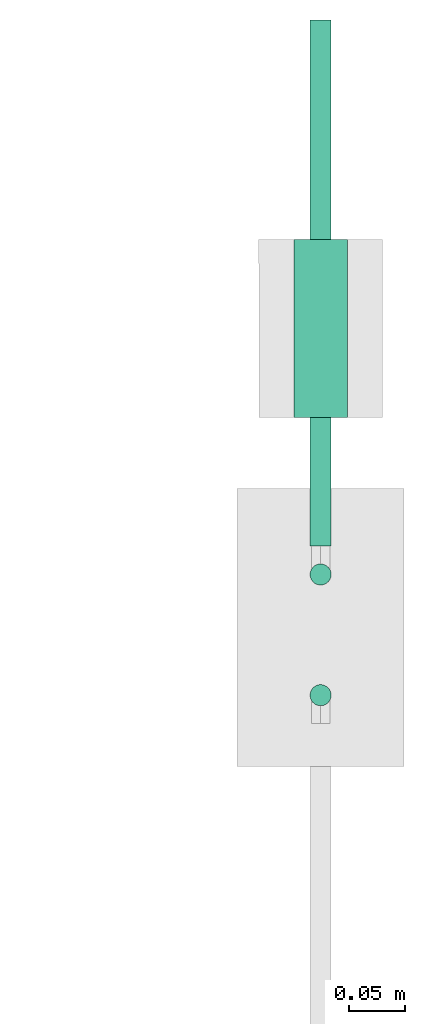
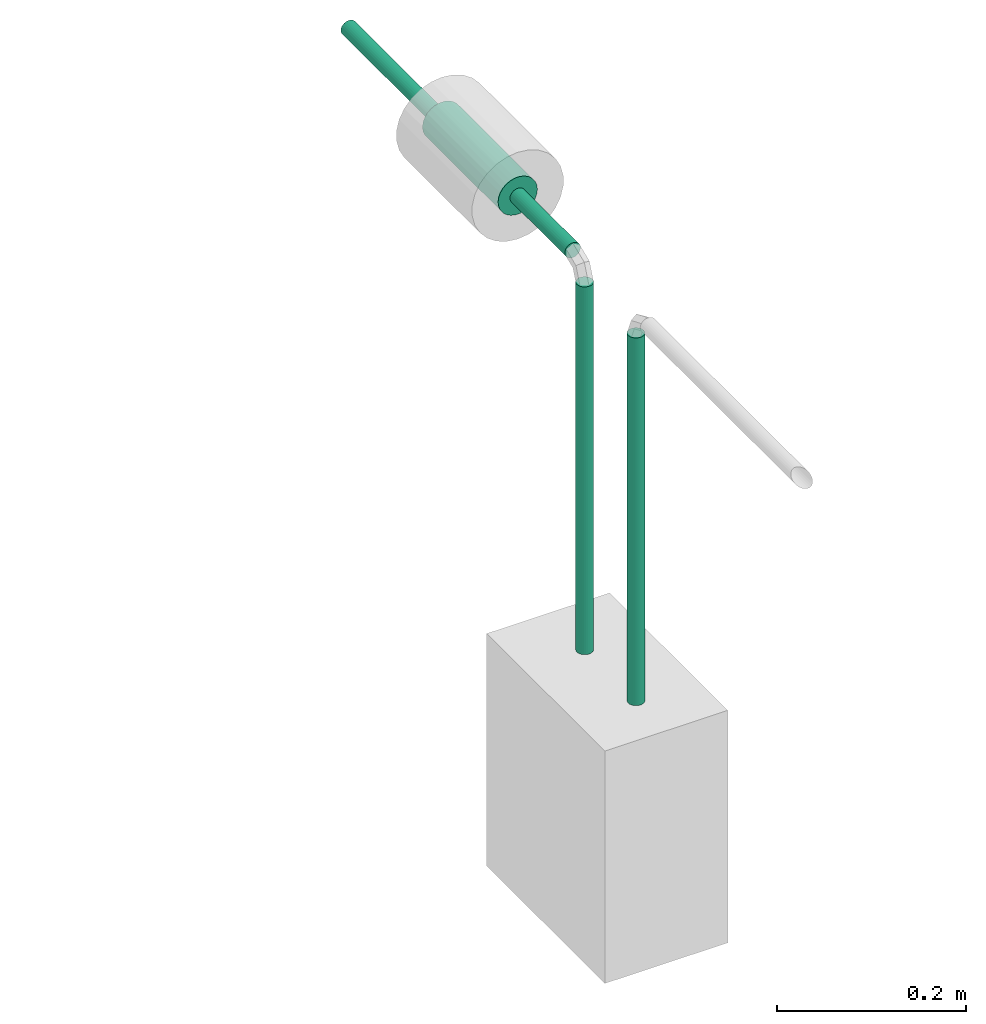
# One storey, part 28 of 45: 4 flow segments.
"""IFC2X3 building model written with IfcOpenShell, lengths in millimetres."""

from ifc_helpers import new_model, entity, si_unit, converted_unit, derived_unit, direction, frame, origin, origin_2d_with_axis, place, context, subcontext, project, spatial, circle, extrude, type_object, element, save


model = new_model("IFC2X3")

# Units and contexts
model_context = context("Model", 3, precision=0.01, world=origin(), true_north=direction((6.12303176911189e-17, 1.0)))
body_context = subcontext(model_context, "Body", "Model", "MODEL_VIEW")
ifc_project = project(units=[si_unit("LENGTHUNIT", "METRE", prefix="MILLI"), si_unit("AREAUNIT", "SQUARE_METRE"), si_unit("VOLUMEUNIT", "CUBIC_METRE"), converted_unit("PLANEANGLEUNIT", "DEGREE", entity("IfcRatioMeasure", 0.0174532925199433), si_unit("PLANEANGLEUNIT", "RADIAN"), dimensions=[0, 0, 0, 0, 0, 0, 0]), si_unit("MASSUNIT", "GRAM", prefix="KILO"), derived_unit("MASSDENSITYUNIT", [(si_unit("MASSUNIT", "GRAM", prefix="KILO"), 1), (si_unit("LENGTHUNIT", "METRE"), -3)]), derived_unit("MOMENTOFINERTIAUNIT", [(si_unit("LENGTHUNIT", "METRE"), 4)]), si_unit("TIMEUNIT", "SECOND"), si_unit("FREQUENCYUNIT", "HERTZ"), si_unit("THERMODYNAMICTEMPERATUREUNIT", "DEGREE_CELSIUS"), derived_unit("THERMALTRANSMITTANCEUNIT", [(si_unit("MASSUNIT", "GRAM", prefix="KILO"), 1), (si_unit("THERMODYNAMICTEMPERATUREUNIT", "KELVIN"), -1), (si_unit("TIMEUNIT", "SECOND"), -3)]), derived_unit("VOLUMETRICFLOWRATEUNIT", [(si_unit("LENGTHUNIT", "METRE"), 3), (si_unit("TIMEUNIT", "SECOND"), -1)]), derived_unit("MASSFLOWRATEUNIT", [(si_unit("MASSUNIT", "GRAM", prefix="KILO"), 1), (si_unit("TIMEUNIT", "SECOND"), -1)]), derived_unit("ROTATIONALFREQUENCYUNIT", [(si_unit("TIMEUNIT", "SECOND"), -1)]), si_unit("ELECTRICCURRENTUNIT", "AMPERE"), si_unit("ELECTRICVOLTAGEUNIT", "VOLT"), si_unit("POWERUNIT", "WATT"), si_unit("FORCEUNIT", "NEWTON", prefix="KILO"), si_unit("ILLUMINANCEUNIT", "LUX"), si_unit("LUMINOUSFLUXUNIT", "LUMEN"), si_unit("LUMINOUSINTENSITYUNIT", "CANDELA"), derived_unit("USERDEFINED", [(si_unit("MASSUNIT", "GRAM", prefix="KILO"), -1), (si_unit("LENGTHUNIT", "METRE"), -2), (si_unit("TIMEUNIT", "SECOND"), 3), (si_unit("LUMINOUSFLUXUNIT", "LUMEN"), 1)]), derived_unit("LINEARVELOCITYUNIT", [(si_unit("LENGTHUNIT", "METRE"), 1), (si_unit("TIMEUNIT", "SECOND"), -1)]), si_unit("PRESSUREUNIT", "PASCAL"), derived_unit("USERDEFINED", [(si_unit("LENGTHUNIT", "METRE"), -2), (si_unit("MASSUNIT", "GRAM", prefix="KILO"), 1), (si_unit("TIMEUNIT", "SECOND"), -2)]), derived_unit("LINEARFORCEUNIT", [(si_unit("MASSUNIT", "GRAM", prefix="KILO"), 1), (si_unit("LENGTHUNIT", "METRE"), 1), (si_unit("TIMEUNIT", "SECOND"), -2), (si_unit("LENGTHUNIT", "METRE"), -1)]), derived_unit("PLANARFORCEUNIT", [(si_unit("MASSUNIT", "GRAM", prefix="KILO"), 1), (si_unit("LENGTHUNIT", "METRE"), 1), (si_unit("TIMEUNIT", "SECOND"), -2), (si_unit("LENGTHUNIT", "METRE"), -2)])], contexts=[model_context])

# Site, building, storey
site_placement = place(None, frame((-24836.06, 8968.75, 0.0)))
site = spatial("IfcSite", under=ifc_project, at=site_placement, CompositionType="ELEMENT")
building_placement = place(site_placement, origin())
building = spatial("IfcBuilding", under=site, at=building_placement, CompositionType="ELEMENT")
storey_placement = place(building_placement, frame((0.0, 0.0, -4200.0)))
storey = spatial("IfcBuildingStorey", under=building, at=storey_placement, CompositionType="ELEMENT", Elevation=-4200.0)

# Flow segments
pipe_segment_type_1 = type_object("IfcPipeSegmentType", PredefinedType="NOTDEFINED")
flow_segment_1_placement = place(storey_placement, frame((98110.13, 1125.13, 1700.0)))
element("IfcFlowSegment", 1, at=flow_segment_1_placement, inside=storey, type_object=pipe_segment_type_1, context=body_context, shape_type="SweptSolid", body=[
    extrude(circle(Radius=9.525, at=origin_2d_with_axis()), frame((11.12, 11.12, 0.0)), (0.0, 0.0, 1.0), 474.599999999999),
])
flow_segment_2_placement = place(storey_placement, frame((98110.13, 1233.72, 1700.0)))
element("IfcFlowSegment", 2, at=flow_segment_2_placement, inside=storey, type_object=pipe_segment_type_1, context=body_context, shape_type="SweptSolid", body=[
    extrude(circle(Radius=9.525, at=origin_2d_with_axis()), frame((11.12, 11.12, 0.0)), (0.0, 0.0, 1.0), 474.600000000001),
])
flow_segment_3_placement = place(storey_placement, frame((98110.02, 1270.24, 2188.88)))
element("IfcFlowSegment", 3, at=flow_segment_3_placement, inside=storey, type_object=pipe_segment_type_1, context=body_context, shape_type="SweptSolid", body=[
    extrude(circle(Radius=9.525, at=origin_2d_with_axis()), frame((11.12, 473.35, 11.12), z_axis=(0.00021819911342732, -0.999999976194573, 0.0), x_axis=(-0.999999976194573, -0.00021819911342732, 0.0)), (0.0, 0.0, 1.0), 473.348613729166),
])
pipe_segment_type_2 = type_object("IfcPipeSegmentType", PredefinedType="NOTDEFINED")
flow_segment_4_placement = place(storey_placement, frame((98095.62, 1386.25, 2174.4)))
element("IfcFlowSegment", 4, at=flow_segment_4_placement, inside=storey, type_object=pipe_segment_type_2, context=body_context, shape_type="SweptSolid", body=[
    extrude(circle(Radius=24.0, at=origin_2d_with_axis()), frame((25.6, 0.0, 25.6), z_axis=(0.0, 1.0, 0.0), x_axis=(-1.0, 0.0, 0.0)), (0.0, 0.0, 1.0), 159.999999999985),
])

save(model, "model.ifc")
